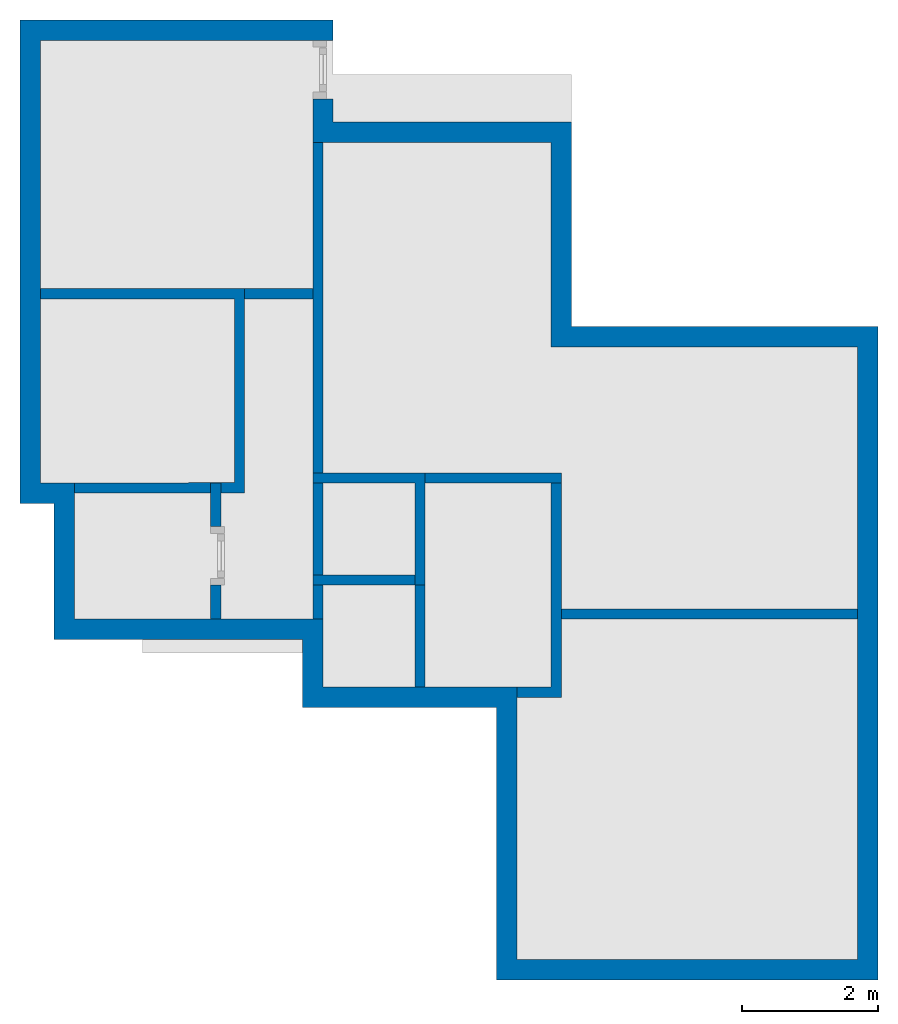
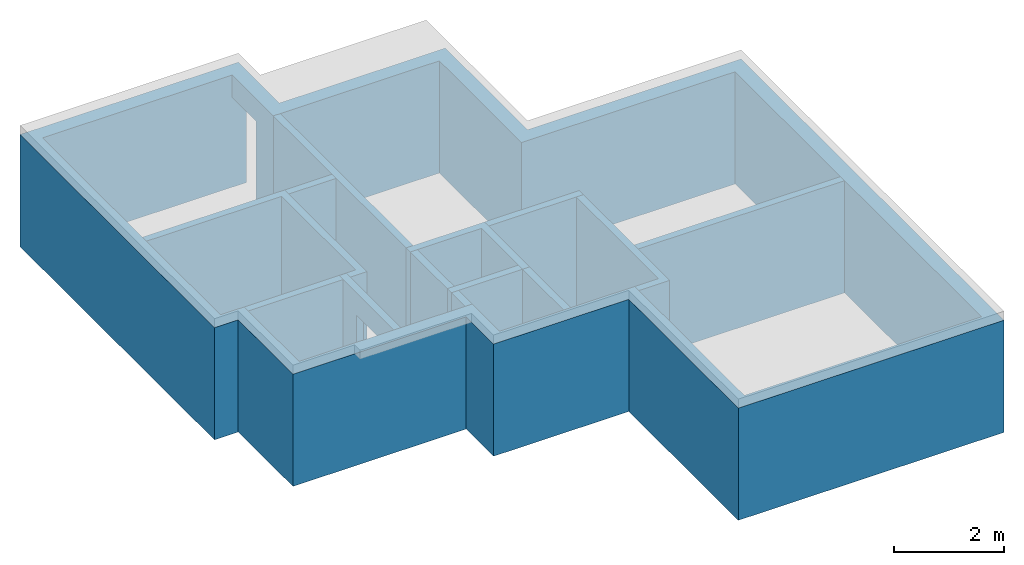
# Not in any storey, part 1 of 3: 11 walls, 2 openings.
"""IFC4 building model written with IfcOpenShell, lengths in metres."""

import ifcopenshell
import ifcopenshell.guid

model = None  # the IFC model being written
_history = None  # IfcOwnerHistory: only IFC2X3 demands one
_inside = {}  # id of a spatial element -> (the spatial element, [elements in it])
_under = {}  # id of a project, library or spatial element -> (it, [spatial elements below it])
_declared = {}  # id of a project -> (the project, [libraries it declares])
_typed = {}  # id of a type object -> (the type object, [elements of that type])
_made_of = {}  # id of a material, layer set ... -> (it, [elements and type objects made of it])


def new_model(schema):
    """Start an empty IFC model of exactly this schema.

    Asked for "IFC4X3", IfcOpenShell would pick the latest addendum, in which some entities
    have other attributes; the version numbers below select the first issue.
    IFC2X3 requires an IfcOwnerHistory on every rooted entity: one is made here for all.
    """
    global model, _history
    if schema == "IFC4X3":
        model = ifcopenshell.file(schema_version=(4, 3, 0, 0))
    else:
        model = ifcopenshell.file(schema=schema)
    _inside.clear()
    _under.clear()
    _declared.clear()
    _typed.clear()
    _made_of.clear()
    _history = None
    if model.schema == "IFC2X3":
        org = make("IfcOrganization", Name="unknown")
        user = make(
            "IfcPersonAndOrganization",
            ThePerson=make("IfcPerson", FamilyName="unknown"),
            TheOrganization=org,
        )
        app = make(
            "IfcApplication",
            ApplicationDeveloper=org,
            Version="unknown",
            ApplicationFullName="unknown",
            ApplicationIdentifier="unknown",
        )
        _history = make(
            "IfcOwnerHistory",
            OwningUser=user,
            OwningApplication=app,
            ChangeAction="ADDED",
            CreationDate=0,
        )
    return model


def make(cls, **values):
    """One entity of the class cls with the attributes given. An attribute that is None is left unset."""
    return model.create_entity(
        cls, **{name: value for name, value in values.items() if value is not None}
    )


def entity(cls, *values):
    """Any entity or typed value of the class cls, its attributes in the order of the schema. None: left unset."""
    e = model.create_entity(cls)
    for i, value in enumerate(values):
        if value is not None:
            e[i] = value
    return e


def rooted(cls, **values):
    """An entity with a GlobalId (a new one), such as an element, a storey or a relation."""
    return make(cls, GlobalId=ifcopenshell.guid.new(), OwnerHistory=_history, **values)


def si_unit(unit_type, name, prefix=None):
    """IfcSIUnit, for example si_unit("LENGTHUNIT", "METRE", prefix="MILLI")."""
    return make("IfcSIUnit", UnitType=unit_type, Prefix=prefix, Name=name)


def converted_unit(unit_type, name, factor, base, dimensions=None, offset=None):
    """IfcConversionBasedUnit, such as the inch: factor (a typed value) times the base unit."""
    return make(
        "IfcConversionBasedUnit"
        if offset is None
        else "IfcConversionBasedUnitWithOffset",
        ConversionOffset=offset,
        Dimensions=None
        if dimensions is None
        else entity("IfcDimensionalExponents", *dimensions),
        UnitType=unit_type,
        Name=name,
        ConversionFactor=make(
            "IfcMeasureWithUnit", ValueComponent=factor, UnitComponent=base
        ),
    )


def assignment(units):
    """IfcUnitAssignment: the units of a project."""
    return None if units is None else make("IfcUnitAssignment", Units=units)


def point(xyz):
    """IfcCartesianPoint."""
    return None if xyz is None else make("IfcCartesianPoint", Coordinates=xyz)


def direction(xyz):
    """IfcDirection."""
    return None if xyz is None else make("IfcDirection", DirectionRatios=xyz)


def frame(location, z_axis=None, x_axis=None):
    """IfcAxis2Placement3D, a coordinate frame: its origin and axes. An axis left out is left unset."""
    return make(
        "IfcAxis2Placement3D",
        Location=point(location),
        Axis=direction(z_axis),
        RefDirection=direction(x_axis),
    )


def frame_2d(location, x_axis=None):
    """IfcAxis2Placement2D, a coordinate frame in the plane: its origin and x axis."""
    return make(
        "IfcAxis2Placement2D", Location=point(location), RefDirection=direction(x_axis)
    )


def origin_with_axes():
    """The frame at (0, 0, 0) with the z axis (0, 0, 1) and the x axis (1, 0, 0) written out."""
    return frame((0.0, 0.0, 0.0), z_axis=(0.0, 0.0, 1.0), x_axis=(1.0, 0.0, 0.0))


def origin_2d_with_axis():
    """The frame at (0, 0) in the plane with the x axis (1, 0) written out."""
    return frame_2d((0.0, 0.0), x_axis=(1.0, 0.0))


def place(relative_to, where):
    """IfcLocalPlacement: puts the frame where relative to a parent placement (None: the world)."""
    return make(
        "IfcLocalPlacement", PlacementRelTo=relative_to, RelativePlacement=where
    )


def context(
    kind, dimensions, precision=None, world=None, true_north=None, identifier=None
):
    """IfcGeometricRepresentationContext, for example the 3D "Model" context."""
    return make(
        "IfcGeometricRepresentationContext",
        ContextIdentifier=identifier,
        ContextType=kind,
        CoordinateSpaceDimension=dimensions,
        Precision=precision,
        WorldCoordinateSystem=world,
        TrueNorth=true_north,
    )


def subcontext(parent, identifier, kind, view, scale=None):
    """IfcGeometricRepresentationSubContext, for example "Body" below "Model"."""
    return make(
        "IfcGeometricRepresentationSubContext",
        ContextIdentifier=identifier,
        ContextType=kind,
        ParentContext=parent,
        TargetScale=scale,
        TargetView=view,
    )


def project(units=None, contexts=None):
    """IfcProject with its units and contexts."""
    return rooted(
        "IfcProject",
        Name="project",
        RepresentationContexts=contexts,
        UnitsInContext=assignment(units),
    )


def spatial(cls, under=None, at=None, **own):
    """A site, building, storey or space (cls), placed at a placement, below another one or the project."""
    s = rooted(cls, ObjectPlacement=at, **own)
    if under is not None:
        _under.setdefault(under.id(), (under, []))[1].append(s)
    return s


def polyline(points):
    """IfcPolyline through the points."""
    return make("IfcPolyline", Points=[point(p) for p in points])


def profile(cls, at=None, kind="AREA", **sizes):
    """A parametric profile (cls). Its sizes go by their IFC names, for example OverallWidth=200.0."""
    return make(cls, ProfileType=kind, Position=at, **sizes)


def rectangle(**sizes):
    """IfcRectangleProfileDef."""
    return profile("IfcRectangleProfileDef", **sizes)


def outline(outer, holes=None, kind="AREA"):
    """IfcArbitraryClosedProfileDef: a profile drawn as a closed curve; with holes, ...WithVoids."""
    if holes is None:
        return make("IfcArbitraryClosedProfileDef", ProfileType=kind, OuterCurve=outer)
    return make(
        "IfcArbitraryProfileDefWithVoids",
        ProfileType=kind,
        OuterCurve=outer,
        InnerCurves=holes,
    )


def extrude(swept, where, along, depth):
    """IfcExtrudedAreaSolid: the profile swept, set in the frame where, extruded along a direction by depth."""
    return make(
        "IfcExtrudedAreaSolid",
        SweptArea=swept,
        Position=where,
        ExtrudedDirection=direction(along),
        Depth=depth,
    )


def faces_of(points, faces, orient=None, outer=None):
    """IfcFace entities. A face is a list of loops; a loop is a list of indices into points, from 0.

    orient and outer hold one flag for each loop. By default every Orientation is true, the
    first loop of a face is its IfcFaceOuterBound and the others are IfcFaceBound.
    """
    made = []
    for i, loops in enumerate(faces):
        bounds = []
        for j, loop in enumerate(loops):
            is_outer = j == 0 if outer is None else outer[i][j]
            bounds.append(
                make(
                    "IfcFaceOuterBound" if is_outer else "IfcFaceBound",
                    Bound=make("IfcPolyLoop", Polygon=[points[k] for k in loop]),
                    Orientation=True if orient is None else orient[i][j],
                )
            )
        made.append(make("IfcFace", Bounds=bounds))
    return made


def faceted_brep(points, faces, orient=None, outer=None, voids=None):
    """IfcFacetedBrep: a solid bounded by flat faces; with voids (closed shells), ...WithVoids."""
    shared = [point(p) for p in points]
    hull = make("IfcClosedShell", CfsFaces=faces_of(shared, faces, orient, outer))
    if voids is None:
        return make("IfcFacetedBrep", Outer=hull)
    return make(
        "IfcFacetedBrepWithVoids",
        Outer=hull,
        Voids=[
            make(cls, CfsFaces=faces_of(shared, fs, o, b)) for cls, fs, o, b in voids
        ],
    )


def shape(context_of_items, identifier, shape_type, items):
    """IfcShapeRepresentation: the items that make up one representation, for example the "Body"."""
    return make(
        "IfcShapeRepresentation",
        ContextOfItems=context_of_items,
        RepresentationIdentifier=identifier,
        RepresentationType=shape_type,
        Items=items,
    )


def made_of(thing, what):
    """Note that an element or type object is made of a material, layer set ...; save() writes the relation."""
    if what is not None:
        _made_of.setdefault(what.id(), (what, []))[1].append(thing)
    return thing


def element(
    cls,
    number,
    at=None,
    inside=None,
    cuts=None,
    type_object=None,
    material=None,
    context=None,
    identifier="Body",
    shape_type=None,
    held_by="IfcProductDefinitionShape",
    body=None,
    shapes=None,
    **own,
):
    """One element of the class cls, such as IfcWall. Its Tag is "e" and its number.

    at: its placement. inside: the storey or other place that contains it. cuts: it is an
    opening in that element (IfcRelVoidsElement). A single representation is given by context,
    identifier, shape_type and body (its items); several are given by shapes. held_by: the class
    of the entity that holds the representations. save() writes the other relations.
    """
    e = rooted(cls, Tag="e%d" % number, ObjectPlacement=at, **own)
    if body is not None:
        shapes = [shape(context, identifier, shape_type, body)]
    if shapes is not None:
        e.Representation = make(held_by, Representations=shapes)
    if inside is not None:
        _inside.setdefault(inside.id(), (inside, []))[1].append(e)
    if cuts is not None:
        rooted(
            "IfcRelVoidsElement", RelatingBuildingElement=cuts, RelatedOpeningElement=e
        )
    if type_object is not None:
        _typed.setdefault(type_object.id(), (type_object, []))[1].append(e)
    return made_of(e, material)


def aggregate(whole, parts):
    """IfcRelAggregates: a whole, such as a stair, and the parts it consists of."""
    return rooted("IfcRelAggregates", RelatingObject=whole, RelatedObjects=parts)


def save(model, path):
    """Write the relations noted so far, then the file.

    IfcRelAggregates (storeys below a building ...), IfcRelContainedInSpatialStructure (elements
    in a storey), IfcRelDefinesByType, IfcRelAssociatesMaterial and IfcRelDeclares: one each for
    every whole, place, type object, material and project.
    """
    for whole, parts in _under.values():
        aggregate(whole, parts)
    for where, things in _inside.values():
        rooted(
            "IfcRelContainedInSpatialStructure",
            RelatedElements=things,
            RelatingStructure=where,
        )
    for kind, things in _typed.values():
        rooted("IfcRelDefinesByType", RelatedObjects=things, RelatingType=kind)
    for what, things in _made_of.values():
        rooted("IfcRelAssociatesMaterial", RelatedObjects=things, RelatingMaterial=what)
    for by, libraries in _declared.values():
        rooted("IfcRelDeclares", RelatingContext=by, RelatedDefinitions=libraries)
    model.write(path)


model = new_model("IFC4")

# Units and contexts
model_context = context("Model", 3, precision=1e-05, world=origin_with_axes(), true_north=direction((0.0, 1.0)))
body_context = subcontext(model_context, "Body", "Model", "MODEL_VIEW")
ifc_project = project(units=[si_unit("LENGTHUNIT", "METRE"), si_unit("AREAUNIT", "SQUARE_METRE"), si_unit("VOLUMEUNIT", "CUBIC_METRE"), converted_unit("PLANEANGLEUNIT", "DEGREE", entity("IfcPlaneAngleMeasure", 0.017453292519943295), si_unit("PLANEANGLEUNIT", "RADIAN"), dimensions=[0, 0, 0, 0, 0, 0, 0])], contexts=[model_context])

# Building
building = spatial("IfcBuilding", under=ifc_project, Name="Default Building", CompositionType="ELEMENT")

# Walls
placement = place(None, origin_with_axes())
element("IfcWall", 1, at=placement, inside=building, Name="Wand", PredefinedType="MOVABLE", context=body_context, shape_type="SweptSolid", body=[
    extrude(rectangle(XDim=7.0, YDim=0.15, at=frame_2d((0.0, 0.0), x_axis=(-1.28865172501134e-16, -1.0))), frame((4.075, 8.5, 0.0), z_axis=(0.0, 0.0, 1.0), x_axis=(1.0, 0.0, 0.0)), (0.0, 0.0, 1.0), 2.5),
])
element("IfcWall", 2, at=placement, inside=building, Name="Wand001", PredefinedType="MOVABLE", context=body_context, shape_type="SweptSolid", body=[
    extrude(rectangle(XDim=1.0, YDim=0.15, at=origin_2d_with_axis()), frame((3.50030046814718, 9.78000811343733, 0.0), z_axis=(0.0, 0.0, 1.0), x_axis=(1.0, 0.0, 0.0)), (0.0, 0.0, 1.0), 2.5),
])
element("IfcWall", 3, at=placement, inside=building, Name="Wand002", PredefinedType="MOVABLE", context=body_context, shape_type="SweptSolid", body=[
    extrude(outline(polyline([(-1.54541395761767, -1.59108021216281), (0.95458604238238, -1.58607239966218), (0.95458604238238, 1.41392760033782), (-2.04541395761762, 1.41392760033782), (-2.04541395761771, 1.26392760033762), (0.804586042382198, 1.26392760033689), (0.804586042382291, -1.43637256747574), (-1.54571442576485, -1.4410805131009), (-1.54541395761767, -1.59108021216281)])), frame((2.04571442576481, 8.44108051309951, 0.0), z_axis=(0.0, 0.0, 1.0), x_axis=(1.0, 0.0, 0.0)), (0.0, 0.0, 1.0), 2.5),
])

# Wall, opening
wall_4 = element("IfcWall", 4, at=placement, inside=building, Name="Wand003", PredefinedType="MOVABLE", context=body_context, shape_type="SweptSolid", body=[
    extrude(rectangle(XDim=2.0, YDim=0.15, at=frame_2d((0.0, 0.0), x_axis=(0.0, -1.0))), frame((2.575, 6.0, 0.0), z_axis=(0.0, 0.0, 1.0), x_axis=(1.0, 0.0, 0.0)), (0.0, 0.0, 1.0), 2.5),
])
element("IfcOpeningElement", 5, at=placement, cuts=wall_4, context=body_context, shape_type="Brep", body=[
    faceted_brep([(0.5, 6.36, 0.0), (4.5, 6.36, 0.0), (4.5, 5.5, 0.0), (0.5, 5.5, 0.0), (4.5, 5.5, 2.0), (0.5, 5.5, 2.0), (4.5, 6.36, 2.0), (0.5, 6.36, 2.0)], [[[0, 1, 2, 3]], [[3, 2, 4, 5]], [[5, 4, 6, 7]], [[7, 6, 1, 0]], [[2, 1, 6, 4]], [[0, 3, 5, 7]]]),
])

# Walls
element("IfcWall", 6, at=placement, inside=building, Name="Wand004", PredefinedType="MOVABLE", context=body_context, shape_type="SweptSolid", body=[
    extrude(rectangle(XDim=1.50000053270021, YDim=0.15, at=frame_2d((0.0, 0.0), x_axis=(0.999999644866656, 0.00084277313820305))), frame((4.74993679201464, 5.57436789328687, 0.0), z_axis=(0.0, 0.0, 1.0), x_axis=(1.0, 0.0, 0.0)), (0.0, 0.0, 1.0), 2.5),
])
element("IfcWall", 7, at=placement, inside=building, Name="Wand005", PredefinedType="MOVABLE", context=body_context, shape_type="SweptSolid", body=[
    extrude(outline(polyline([(-1.1821428571429, 0.317857142857104), (0.317857142857143, 0.317857142857143), (0.317857142857143, -1.18214285714286), (0.467857142856922, -1.18214285714308), (0.467857142856883, 0.467857142856701), (-1.18214285714294, 0.467857142856883), (-1.1821428571429, 0.317857142857104)])), frame((5.18214285714286, 6.68214285714286, 0.0), z_axis=(0.0, 0.0, 1.0), x_axis=(1.0, 0.0, 0.0)), (0.0, 0.0, 1.0), 2.5),
])
element("IfcWall", 8, at=placement, inside=building, Name="Wand006", PredefinedType="MOVABLE", context=body_context, shape_type="SweptSolid", body=[
    extrude(rectangle(XDim=1.5, YDim=0.15, at=frame_2d((0.0, 0.0), x_axis=(0.0, -1.0))), frame((5.575, 4.75, 0.0), z_axis=(0.0, 0.0, 1.0), x_axis=(1.0, 0.0, 0.0)), (0.0, 0.0, 1.0), 2.5),
])
element("IfcWall", 9, at=placement, inside=building, Name="Wand007", PredefinedType="MOVABLE", context=body_context, shape_type="SweptSolid", body=[
    extrude(rectangle(XDim=2.0, YDim=0.15, at=origin_2d_with_axis()), frame((6.65, 7.075, 0.0), z_axis=(0.0, 0.0, 1.0), x_axis=(1.0, 0.0, 0.0)), (0.0, 0.0, 1.0), 2.5),
])
element("IfcWall", 10, at=placement, inside=building, Name="Wand008", PredefinedType="MOVABLE", context=body_context, shape_type="SweptSolid", body=[
    extrude(outline(polyline([(-0.0304794520545729, 1.78047945205457), (-0.0304794520547948, -1.21952054794521), (-0.530479452054795, -1.21952054794521), (-0.530479452054755, -1.36952054794525), (0.119520547945285, -1.36952054794547), (0.119520547945467, 1.78047945205435), (-0.0304794520545729, 1.78047945205457)])), frame((7.5304794520548, 5.21952054794521, 0.0), z_axis=(0.0, 0.0, 1.0), x_axis=(1.0, 0.0, 0.0)), (0.0, 0.0, 1.0), 2.5),
])
element("IfcWall", 11, at=placement, inside=building, Name="Wand009", PredefinedType="MOVABLE", context=body_context, shape_type="SweptSolid", body=[
    extrude(rectangle(XDim=4.5, YDim=0.15, at=origin_2d_with_axis()), frame((9.75, 5.075, 0.0), z_axis=(0.0, 0.0, 1.0), x_axis=(1.0, 0.0, 0.0)), (0.0, 0.0, 1.0), 2.5),
])

# Wall, opening
wall_11 = element("IfcWall", 12, at=placement, inside=building, Name="Wand010", PredefinedType="MOVABLE", context=body_context, shape_type="SweptSolid", body=[
    extrude(outline(polyline([(0.553448275862072, -3.19655172413794), (0.553448275862072, -7.19655172413794), (6.15344827586207, -7.19655172413794), (6.15344827586207, 2.40344827586206), (1.65344827586207, 2.40344827586206), (1.65344827586207, 5.40344827586206), (-1.84655172413793, 5.40344827586206), (-1.84655172413793, 6.90344827586206), (-6.44655172413793, 6.90344827586206), (-6.44655172413793, -0.196551724137936), (-5.94655172413793, -0.196551724137936), (-5.94655172413793, -2.19655172413794), (-2.29655172413793, -2.19655172413794), (-2.29655172413793, -3.19655172413794), (0.553448275862072, -3.19655172413794)]), holes=[polyline([(0.853448275862073, -6.89655172413794), (5.85344827586207, -6.89655172413794), (5.85344827586207, 2.10344827586206), (1.35344827586207, 2.10344827586206), (1.35344827586207, 5.10344827586206), (-2.14655172413793, 5.10344827586206), (-2.14655172413793, 6.60344827586206), (-6.14655172413793, 6.60344827586206), (-6.14655172413793, 0.103448275862064), (-5.64655172413793, 0.103448275862064), (-5.64655172413793, -1.89655172413794), (-1.99655172413793, -1.89655172413794), (-1.99655172413793, -2.89655172413794), (0.853448275862073, -2.89655172413794), (0.853448275862073, -6.89655172413794)])]), frame((6.14655172413793, 6.89655172413794, -3.26137309717496e-18), z_axis=(0.0, 0.0, 1.0), x_axis=(1.0, 0.0, 0.0)), (0.0, 0.0, 1.0), 2.5),
])
element("IfcOpeningElement", 13, at=placement, cuts=wall_11, context=body_context, shape_type="Brep", body=[
    faceted_brep([(2.0, 13.5, 0.0), (6.0, 13.5, 0.0), (6.0, 12.64, 0.0), (2.0, 12.64, 0.0), (6.0, 12.64, 2.0), (2.0, 12.64, 2.0), (6.0, 13.5, 2.0), (2.0, 13.5, 2.0)], [[[0, 1, 2, 3]], [[3, 2, 4, 5]], [[5, 4, 6, 7]], [[7, 6, 1, 0]], [[2, 1, 6, 4]], [[0, 3, 5, 7]]]),
])

save(model, "model.ifc")
